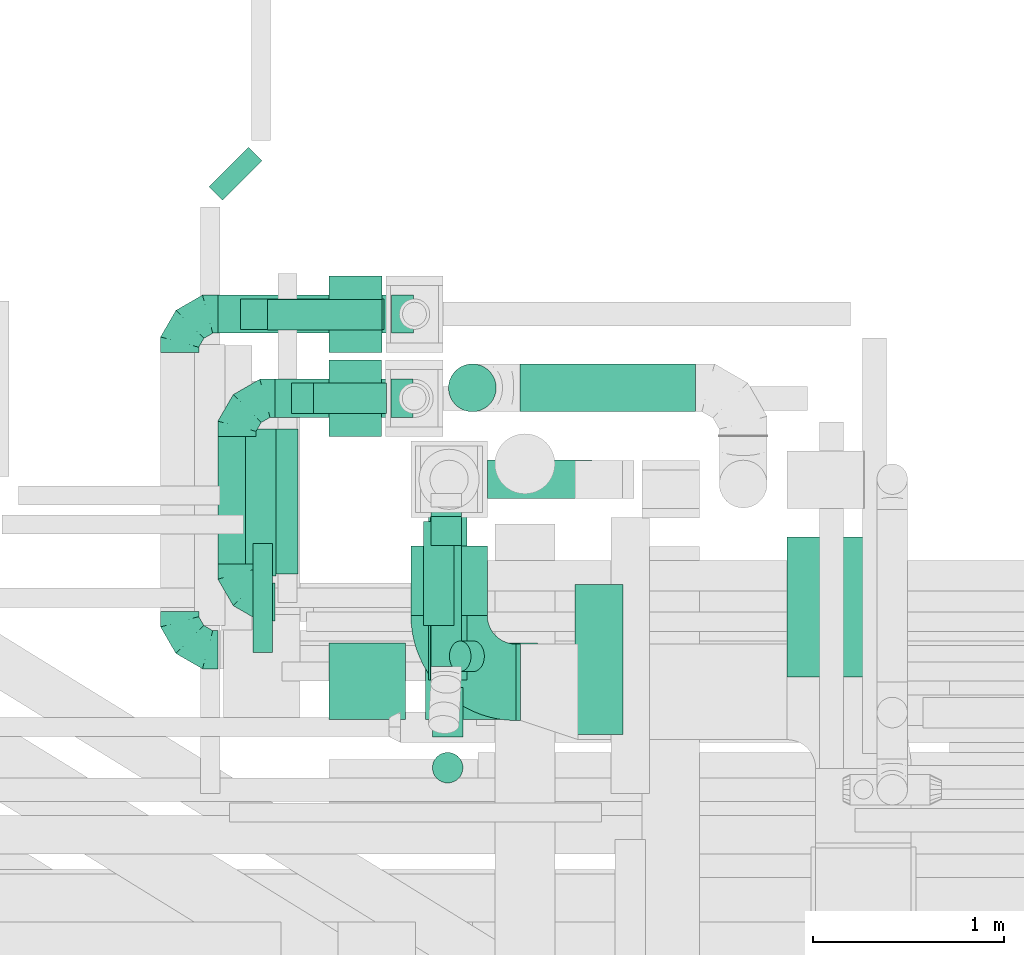
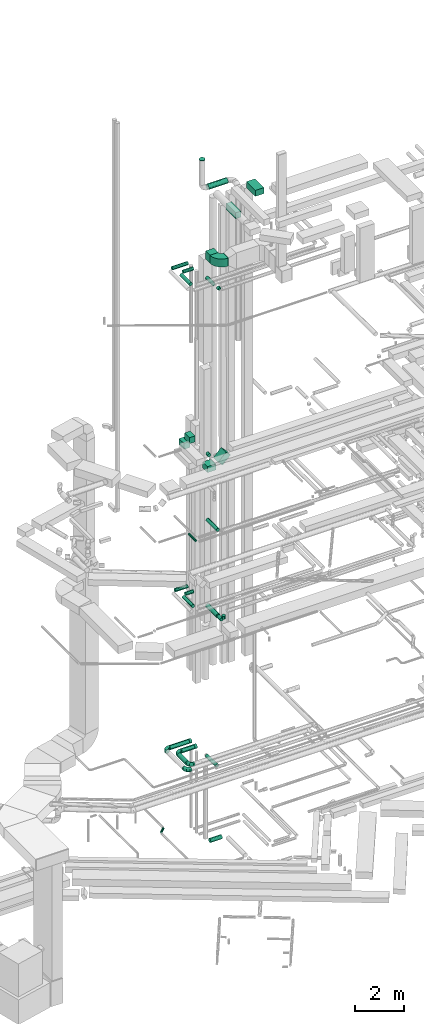
# One storey, part 97 of 337: 29 flow segments, 8 flow fittings.
"""IFC2X3 building model written with IfcOpenShell, lengths in millimetres."""

from ifc_helpers import new_model, entity, si_unit, converted_unit, derived_unit, direction, frame, frame_2d, origin, origin_2d_with_axis, place, context, subcontext, project, spatial, polyline, circle_curve, parameter, trimmed, segment, composite_curve, rectangle, circle, outline, extrude, faceted_brep, source, transform, mapped, material, type_object, type_shapes, element, save


model = new_model("IFC2X3")

# Units and contexts
model_context = context("Model", 3, precision=0.01, world=origin(), true_north=direction((6.12303176911189e-17, 1.0)))
body_context = subcontext(model_context, "Body", "Model", "MODEL_VIEW")
ifc_project = project(units=[si_unit("LENGTHUNIT", "METRE", prefix="MILLI"), si_unit("AREAUNIT", "SQUARE_METRE"), si_unit("VOLUMEUNIT", "CUBIC_METRE"), converted_unit("PLANEANGLEUNIT", "DEGREE", entity("IfcRatioMeasure", 0.0174532925199433), si_unit("PLANEANGLEUNIT", "RADIAN"), dimensions=[0, 0, 0, 0, 0, 0, 0]), si_unit("MASSUNIT", "GRAM", prefix="KILO"), derived_unit("MASSDENSITYUNIT", [(si_unit("MASSUNIT", "GRAM", prefix="KILO"), 1), (si_unit("LENGTHUNIT", "METRE"), -3)]), derived_unit("MOMENTOFINERTIAUNIT", [(si_unit("LENGTHUNIT", "METRE"), 4)]), si_unit("TIMEUNIT", "SECOND"), si_unit("FREQUENCYUNIT", "HERTZ"), si_unit("THERMODYNAMICTEMPERATUREUNIT", "DEGREE_CELSIUS"), derived_unit("THERMALTRANSMITTANCEUNIT", [(si_unit("MASSUNIT", "GRAM", prefix="KILO"), 1), (si_unit("THERMODYNAMICTEMPERATUREUNIT", "KELVIN"), -1), (si_unit("TIMEUNIT", "SECOND"), -3)]), derived_unit("VOLUMETRICFLOWRATEUNIT", [(si_unit("LENGTHUNIT", "METRE"), 3), (si_unit("TIMEUNIT", "SECOND"), -1)]), derived_unit("MASSFLOWRATEUNIT", [(si_unit("MASSUNIT", "GRAM", prefix="KILO"), 1), (si_unit("TIMEUNIT", "SECOND"), -1)]), derived_unit("ROTATIONALFREQUENCYUNIT", [(si_unit("TIMEUNIT", "SECOND"), -1)]), si_unit("ELECTRICCURRENTUNIT", "AMPERE"), si_unit("ELECTRICVOLTAGEUNIT", "VOLT"), si_unit("POWERUNIT", "WATT"), si_unit("FORCEUNIT", "NEWTON", prefix="KILO"), si_unit("ILLUMINANCEUNIT", "LUX"), si_unit("LUMINOUSFLUXUNIT", "LUMEN"), si_unit("LUMINOUSINTENSITYUNIT", "CANDELA"), derived_unit("USERDEFINED", [(si_unit("MASSUNIT", "GRAM", prefix="KILO"), -1), (si_unit("LENGTHUNIT", "METRE"), -2), (si_unit("TIMEUNIT", "SECOND"), 3), (si_unit("LUMINOUSFLUXUNIT", "LUMEN"), 1)]), derived_unit("LINEARVELOCITYUNIT", [(si_unit("LENGTHUNIT", "METRE"), 1), (si_unit("TIMEUNIT", "SECOND"), -1)]), si_unit("PRESSUREUNIT", "PASCAL"), derived_unit("USERDEFINED", [(si_unit("LENGTHUNIT", "METRE"), -2), (si_unit("MASSUNIT", "GRAM", prefix="KILO"), 1), (si_unit("TIMEUNIT", "SECOND"), -2)]), derived_unit("LINEARFORCEUNIT", [(si_unit("MASSUNIT", "GRAM", prefix="KILO"), 1), (si_unit("LENGTHUNIT", "METRE"), 1), (si_unit("TIMEUNIT", "SECOND"), -2), (si_unit("LENGTHUNIT", "METRE"), -1)]), derived_unit("PLANARFORCEUNIT", [(si_unit("MASSUNIT", "GRAM", prefix="KILO"), 1), (si_unit("LENGTHUNIT", "METRE"), 1), (si_unit("TIMEUNIT", "SECOND"), -2), (si_unit("LENGTHUNIT", "METRE"), -2)])], contexts=[model_context])

# Site, building, storey
site_placement = place(None, origin())
site = spatial("IfcSite", under=ifc_project, at=site_placement, CompositionType="ELEMENT")
building_placement = place(site_placement, origin())
building = spatial("IfcBuilding", under=site, at=building_placement, CompositionType="ELEMENT")
storey_placement = place(building_placement, origin())
storey = spatial("IfcBuildingStorey", under=building, at=storey_placement, CompositionType="ELEMENT", Elevation=0.0)

# Flow segments
duct_segment_type_1 = type_object("IfcDuctSegmentType", PredefinedType="NOTDEFINED")
flow_segment_1_placement = place(storey_placement, frame((7575.26, 14600.63, 18500.0)))
element("IfcFlowSegment", 1, at=flow_segment_1_placement, inside=storey, type_object=duct_segment_type_1, context=body_context, shape_type="SweptSolid", body=[
    extrude(rectangle(XDim=278.301854356644, YDim=400.0, at=origin_2d_with_axis()), frame((139.15, 200.0, 0.0), z_axis=(0.0, 0.0, 1.0), x_axis=(-1.0, 0.0, 0.0)), (0.0, 0.0, 1.0), 300.000000000001),
])
flow_segment_2_placement = place(storey_placement, frame((7574.85, 14159.28, 19050.0)))
element("IfcFlowSegment", 2, at=flow_segment_2_placement, inside=storey, type_object=duct_segment_type_1, context=body_context, shape_type="SweptSolid", body=[
    extrude(rectangle(XDim=276.813591924487, YDim=400.0, at=origin_2d_with_axis()), frame((138.41, 200.0, 0.0), z_axis=(0.0, 0.0, 1.0), x_axis=(-1.0, 0.0, 0.0)), (0.0, 0.0, 1.0), 300.000000000001),
])
flow_segment_3_placement = place(storey_placement, frame((8082.06, 12678.06, 18631.8)))
element("IfcFlowSegment", 3, at=flow_segment_3_placement, inside=storey, type_object=duct_segment_type_1, context=body_context, shape_type="SweptSolid", body=[
    extrude(rectangle(XDim=300.000000000002, YDim=400.000000000002, at=frame_2d((0.0, 0.0), x_axis=(0.0, 1.0))), frame((106.07, 200.0, 106.07), z_axis=(0.70710678118651, 0.0, 0.707106781186585), x_axis=(0.0, 1.0, 0.0)), (0.0, 0.0, 1.0), 529.2893218813),
])
flow_segment_4_placement = place(storey_placement, frame((7575.26, 12678.06, 18500.0)))
element("IfcFlowSegment", 4, at=flow_segment_4_placement, inside=storey, type_object=duct_segment_type_1, context=body_context, shape_type="SweptSolid", body=[
    extrude(rectangle(XDim=400.735931288126, YDim=400.0, at=origin_2d_with_axis()), frame((200.37, 200.0, 0.0)), (0.0, 0.0, 1.0), 300.000000000001),
])
flow_segment_5_placement = place(storey_placement, frame((8004.69, 13222.81, 28500.0)))
element("IfcFlowSegment", 5, at=flow_segment_5_placement, inside=storey, type_object=duct_segment_type_1, context=body_context, shape_type="SweptSolid", body=[
    extrude(rectangle(XDim=362.88164353834, YDim=400.0, at=origin_2d_with_axis()), frame((200.0, 181.44, 0.0), z_axis=(0.0, 0.0, 1.0), x_axis=(0.0, 1.0, 0.0)), (0.0, 0.0, 1.0), 399.999999999996),
])
flow_segment_6_placement = place(storey_placement, frame((8554.69, 12672.81, 28500.0)))
element("IfcFlowSegment", 6, at=flow_segment_6_placement, inside=storey, type_object=duct_segment_type_1, context=body_context, shape_type="SweptSolid", body=[
    extrude(rectangle(XDim=25.0000000006874, YDim=400.0, at=origin_2d_with_axis()), frame((12.5, 200.0, 0.0)), (0.0, 0.0, 1.0), 399.999999999996),
])
duct_segment_type_2 = type_object("IfcDuctSegmentType", PredefinedType="NOTDEFINED")
flow_segment_7_placement = place(storey_placement, frame((8404.69, 13834.09, -1051.6)))
element("IfcFlowSegment", 7, at=flow_segment_7_placement, inside=storey, type_object=duct_segment_type_2, context=body_context, shape_type="SweptSolid", body=[
    extrude(circle(Radius=100.0, at=origin_2d_with_axis()), frame((0.0, 101.6, 101.6), z_axis=(1.0, 0.0, 0.0), x_axis=(0.0, 1.0, 0.0)), (0.0, 0.0, 1.0), 548.553559999927),
])
flow_segment_8_placement = place(storey_placement, frame((6946.37, 15395.93, -1001.6)))
element("IfcFlowSegment", 8, at=flow_segment_8_placement, inside=storey, type_object=duct_segment_type_2, context=body_context, shape_type="SweptSolid", body=[
    extrude(circle(Radius=50.0, at=origin_2d_with_axis()), frame((36.95, 36.95, 51.6), z_axis=(0.707106781186605, 0.70710678118649, 0.0), x_axis=(0.70710678118649, -0.707106781186605, 0.0)), (0.0, 0.0, 1.0), 291.818961050026),
])
flow_segment_9_placement = place(storey_placement, frame((8095.73, 12885.69, 10898.4)))
element("IfcFlowSegment", 9, at=flow_segment_9_placement, inside=storey, type_object=duct_segment_type_2, context=body_context, shape_type="SweptSolid", body=[
    extrude(circle(Radius=100.0, at=origin_2d_with_axis()), frame((101.6, 0.0, 101.6), z_axis=(0.0, 1.0, 0.0), x_axis=(-1.0, 0.0, 0.0)), (0.0, 0.0, 1.0), 855.000000000102),
])
flow_segment_10_placement = place(storey_placement, frame((7493.56, 14278.67, 11368.4)))
element("IfcFlowSegment", 10, at=flow_segment_10_placement, inside=storey, type_object=duct_segment_type_2, context=body_context, shape_type="SweptSolid", body=[
    extrude(circle(Radius=80.0, at=origin_2d_with_axis()), frame((0.0, 81.6, 81.6), z_axis=(1.0, 0.0, 0.0), x_axis=(0.0, -1.0, 0.0)), (0.0, 0.0, 1.0), 383.103797171607),
])
flow_segment_11_placement = place(storey_placement, frame((7251.97, 13440.27, 11368.4)))
element("IfcFlowSegment", 11, at=flow_segment_11_placement, inside=storey, type_object=duct_segment_type_2, context=body_context, shape_type="SweptSolid", body=[
    extrude(circle(Radius=80.0, at=origin_2d_with_axis()), frame((81.6, 0.0, 81.6), z_axis=(0.0, 1.0, 0.0), x_axis=(-1.0, 0.0, 0.0)), (0.0, 0.0, 1.0), 760.000000000037),
])
flow_segment_12_placement = place(storey_placement, frame((7294.17, 14258.03, 3558.4)))
element("IfcFlowSegment", 12, at=flow_segment_12_placement, inside=storey, type_object=duct_segment_type_2, context=body_context, shape_type="SweptSolid", body=[
    extrude(circle(Radius=100.0, at=origin_2d_with_axis()), frame((0.0, 101.6, 101.6), z_axis=(1.0, 0.0, 0.0), x_axis=(0.0, -1.0, 0.0)), (0.0, 0.0, 1.0), 607.500000000005),
])
flow_segment_13_placement = place(storey_placement, frame((6992.57, 13493.38, 3558.4)))
element("IfcFlowSegment", 13, at=flow_segment_13_placement, inside=storey, type_object=duct_segment_type_2, context=body_context, shape_type="SweptSolid", body=[
    extrude(circle(Radius=100.0, at=origin_2d_with_axis()), frame((101.6, 0.0, 101.6), z_axis=(0.0, 1.0, 0.0), x_axis=(-1.0, 0.0, 0.0)), (0.0, 0.0, 1.0), 666.250000000018),
])
flow_segment_14_placement = place(storey_placement, frame((6994.13, 14698.87, 3558.4)))
element("IfcFlowSegment", 14, at=flow_segment_14_placement, inside=storey, type_object=duct_segment_type_2, context=body_context, shape_type="SweptSolid", body=[
    extrude(circle(Radius=100.0, at=origin_2d_with_axis()), frame((0.0, 101.6, 101.6), z_axis=(1.0, 0.0, 0.0), x_axis=(0.0, -1.0, 0.0)), (0.0, 0.0, 1.0), 909.40808920135),
])
flow_segment_15_placement = place(storey_placement, frame((8108.1, 12956.4, 3378.4)))
element("IfcFlowSegment", 15, at=flow_segment_15_placement, inside=storey, type_object=duct_segment_type_2, context=body_context, shape_type="SweptSolid", body=[
    extrude(circle(Radius=80.0, at=origin_2d_with_axis()), frame((81.6, 0.0, 81.6), z_axis=(0.0, 1.0, 0.0), x_axis=(-1.0, 0.0, 0.0)), (0.0, 0.0, 1.0), 835.195242005169),
])
flow_segment_16_placement = place(storey_placement, frame((8105.73, 12885.69, 15218.4)))
element("IfcFlowSegment", 16, at=flow_segment_16_placement, inside=storey, type_object=duct_segment_type_2, context=body_context, shape_type="SweptSolid", body=[
    extrude(circle(Radius=80.0, at=origin_2d_with_axis()), frame((81.6, 0.0, 81.6), z_axis=(0.0, 1.0, 0.0), x_axis=(1.0, 0.0, 0.0)), (0.0, 0.0, 1.0), 855.00000000004),
])
flow_segment_17_placement = place(storey_placement, frame((7177.72, 13030.0, 14948.4)))
element("IfcFlowSegment", 17, at=flow_segment_17_placement, inside=storey, type_object=duct_segment_type_2, context=body_context, shape_type="SweptSolid", body=[
    extrude(circle(Radius=50.0, at=origin_2d_with_axis()), frame((51.6, 0.0, 51.6), z_axis=(0.0, 1.0, 0.0), x_axis=(1.0, 0.0, 0.0)), (0.0, 0.0, 1.0), 570.000000000031),
])
flow_segment_18_placement = place(storey_placement, frame((7253.56, 14715.12, 11368.4)))
element("IfcFlowSegment", 18, at=flow_segment_18_placement, inside=storey, type_object=duct_segment_type_2, context=body_context, shape_type="SweptSolid", body=[
    extrude(circle(Radius=80.0, at=origin_2d_with_axis()), frame((0.0, 81.6, 81.6), z_axis=(1.0, 0.0, 0.0), x_axis=(0.0, -1.0, 0.0)), (0.0, 0.0, 1.0), 599.999999999878),
])
flow_segment_19_placement = place(storey_placement, frame((8115.73, 12585.69, 10918.4)))
element("IfcFlowSegment", 19, at=flow_segment_19_placement, inside=storey, type_object=duct_segment_type_2, context=body_context, shape_type="SweptSolid", body=[
    extrude(circle(Radius=80.0, at=origin_2d_with_axis()), frame((81.6, 0.0, 81.6), z_axis=(0.0, 1.0, 0.0), x_axis=(-1.0, 0.0, 0.0)), (0.0, 0.0, 1.0), 260.000000000025),
])
flow_segment_20_placement = place(storey_placement, frame((8115.73, 12344.09, 11160.0)))
element("IfcFlowSegment", 20, at=flow_segment_20_placement, inside=storey, type_object=duct_segment_type_2, context=body_context, shape_type="SweptSolid", body=[
    extrude(circle(Radius=80.0, at=origin_2d_with_axis()), frame((81.6, 81.6, 0.0)), (0.0, 0.0, 1.0), 150.000000000053),
])
flow_segment_21_placement = place(storey_placement, frame((8108.1, 13590.35, 18528.4)))
element("IfcFlowSegment", 21, at=flow_segment_21_placement, inside=storey, type_object=duct_segment_type_2, context=body_context, shape_type="SweptSolid", body=[
    extrude(circle(Radius=80.0, at=origin_2d_with_axis()), frame((81.6, 0.0, 81.6), z_axis=(0.0, 1.0, 0.0), x_axis=(-1.0, 0.0, 0.0)), (0.0, 0.0, 1.0), 150.340764961465),
])
flow_segment_22_placement = place(storey_placement, frame((7112.18, 14718.87, 27518.4)))
element("IfcFlowSegment", 22, at=flow_segment_22_placement, inside=storey, type_object=duct_segment_type_2, context=body_context, shape_type="SweptSolid", body=[
    extrude(circle(Radius=80.0, at=origin_2d_with_axis()), frame((0.0, 81.6, 81.6), z_axis=(1.0, 0.0, 0.0), x_axis=(0.0, 1.0, 0.0)), (0.0, 0.0, 1.0), 751.379026910381),
])
flow_segment_23_placement = place(storey_placement, frame((7379.47, 14277.83, 27518.4)))
element("IfcFlowSegment", 23, at=flow_segment_23_placement, inside=storey, type_object=duct_segment_type_2, context=body_context, shape_type="SweptSolid", body=[
    extrude(circle(Radius=80.0, at=origin_2d_with_axis()), frame((0.0, 81.6, 81.6), z_axis=(1.0, 0.0, 0.0), x_axis=(0.0, 1.0, 0.0)), (0.0, 0.0, 1.0), 482.196560462836),
])
flow_segment_24_placement = place(storey_placement, frame((7137.84, 13429.96, 27518.4)))
element("IfcFlowSegment", 24, at=flow_segment_24_placement, inside=storey, type_object=duct_segment_type_2, context=body_context, shape_type="SweptSolid", body=[
    extrude(circle(Radius=80.0, at=origin_2d_with_axis()), frame((81.6, 0.0, 81.6), z_axis=(0.0, 1.0, 0.0), x_axis=(-1.0, 0.0, 0.0)), (0.0, 0.0, 1.0), 769.468388366114),
])
flow_segment_25_placement = place(storey_placement, frame((8068.1, 13169.26, 27348.4)))
element("IfcFlowSegment", 25, at=flow_segment_25_placement, inside=storey, type_object=duct_segment_type_2, context=body_context, shape_type="SweptSolid", body=[
    extrude(circle(Radius=80.0, at=origin_2d_with_axis()), frame((81.6, 0.0, 81.6), z_axis=(0.0, 1.0, 0.0), x_axis=(-1.0, 0.0, 0.0)), (0.0, 0.0, 1.0), 546.426253024174),
])
flow_segment_26_placement = place(storey_placement, frame((8576.39, 14288.14, 31273.7)))
element("IfcFlowSegment", 26, at=flow_segment_26_placement, inside=storey, type_object=duct_segment_type_2, context=body_context, shape_type="SweptSolid", body=[
    extrude(circle(Radius=125.0, at=origin_2d_with_axis()), frame((0.0, 126.6, 126.6), z_axis=(1.0, 0.0, 0.0), x_axis=(0.0, 1.0, 0.0)), (0.0, 0.0, 1.0), 918.063977471099),
])
flow_segment_27_placement = place(storey_placement, frame((8204.67, 12927.67, 27188.7)))
element("IfcFlowSegment", 27, at=flow_segment_27_placement, inside=storey, type_object=duct_segment_type_2, context=body_context, shape_type="SweptSolid", body=[
    extrude(circle(Radius=80.0, at=origin_2d_with_axis()), frame((58.16, 81.6, 128.16), z_axis=(0.707106781186541, 0.0, -0.707106781186554), x_axis=(0.0, 1.0, 0.0)), (0.0, 0.0, 1.0), 98.9949493661142),
])
duct_segment_type_3 = type_object("IfcDuctSegmentType", PredefinedType="NOTDEFINED")
flow_segment_28_placement = place(storey_placement, frame((9973.95, 12899.6, 31350.0)))
element("IfcFlowSegment", 28, at=flow_segment_28_placement, inside=storey, type_object=duct_segment_type_3, context=body_context, shape_type="SweptSolid", body=[
    extrude(rectangle(XDim=734.413460000079, YDim=400.0, at=origin_2d_with_axis()), frame((200.0, 367.21, 0.0), z_axis=(0.0, 0.0, 1.0), x_axis=(0.0, 1.0, 0.0)), (0.0, 0.0, 1.0), 300.000000000001),
])
flow_segment_29_placement = place(storey_placement, frame((8863.91, 12599.6, 30800.0)))
element("IfcFlowSegment", 29, at=flow_segment_29_placement, inside=storey, type_object=duct_segment_type_3, context=body_context, shape_type="SweptSolid", body=[
    extrude(rectangle(XDim=784.286964999949, YDim=250.000000000001, at=origin_2d_with_axis()), frame((125.0, 392.14, 0.0), z_axis=(0.0, 0.0, 1.0), x_axis=(0.0, 1.0, 0.0)), (0.0, 0.0, 1.0), 300.000000000001),
])

# Flow fittings
ifc_material = material()
duct_fitting_type_1 = type_object("IfcDuctFittingType", PredefinedType="NOTDEFINED", material=ifc_material)
shared_shape_1 = source(origin(), body_context, "Body", "SweptSolid", [
    extrude(circle(Radius=124.999999999999, at=origin_2d_with_axis()), frame((0.0, 0.0, 0.0), z_axis=(1.0, 0.0, 0.0), x_axis=(0.0, 1.0, 0.0)), (0.0, 0.0, 1.0), 25.0000000000018),
])
type_shapes(duct_fitting_type_1, [shared_shape_1])
flow_fitting_1_placement = place(storey_placement, frame((8326.39, 14414.61, 32860.29), z_axis=(0.0, -1.0, 0.0), x_axis=(0.0, 0.0, 1.0)))
element("IfcFlowFitting", 30, at=flow_fitting_1_placement, inside=storey, type_object=duct_fitting_type_1, material=ifc_material, context=body_context, shape_type="MappedRepresentation", body=[
    mapped(shared_shape_1, transform((0.0, 0.0, 0.0), scale=1.0)),
])
duct_fitting_type_2 = type_object("IfcDuctFittingType", PredefinedType="NOTDEFINED", material=ifc_material)
shared_shape_2 = source(origin(), body_context, "Body", "Brep", [
    faceted_brep([(-200.0, 0.0, -100.0), (-200.0, -25.88, -96.59), (-200.0, -50.0, -86.6), (-200.0, -70.71, -70.71), (-200.0, -86.6, -50.0), (-200.0, -96.59, -25.88), (-200.0, -100.0, 0.0), (-200.0, -96.59, 25.88), (-200.0, -86.6, 50.0), (-200.0, -70.71, 70.71), (-200.0, -50.0, 86.6), (-200.0, -25.88, 96.59), (-200.0, 0.0, 100.0), (-200.0, 25.88, 96.59), (-200.0, 50.0, 86.6), (-200.0, 70.71, 70.71), (-200.0, 86.6, 50.0), (-200.0, 96.59, 25.88), (-200.0, 100.0, 0.0), (-200.0, 96.59, -25.88), (-200.0, 86.6, -50.0), (-200.0, 70.71, -70.71), (-200.0, 50.0, -86.6), (-200.0, 25.88, -96.59), (-153.35, 25.88, 96.59), (-159.81, 50.0, 86.6), (-146.41, 0.0, 100.0), (-165.36, 70.71, 70.71), (-172.29, 96.59, 25.88), (-173.21, 100.0, 0.0), (-169.62, 86.6, 50.0), (-169.62, 86.6, -50.0), (-165.36, 70.71, -70.71), (-172.29, 96.59, -25.88), (-153.35, 25.88, -96.59), (-146.41, 0.0, -100.0), (-159.81, 50.0, -86.6), (-139.48, -25.88, -96.59), (-133.01, -50.0, -86.6), (-127.46, -70.71, -70.71), (-123.21, -86.6, -50.0), (-120.53, -96.59, -25.88), (-119.62, -100.0, 0.0), (-120.53, -96.59, 25.88), (-123.21, -86.6, 50.0), (-127.46, -70.71, 70.71), (-133.01, -50.0, 86.6), (-139.48, -25.88, 96.59), (-72.54, 72.54, 96.59), (-90.19, 90.19, 86.6), (-53.59, 53.59, 100.0), (-105.35, 105.35, 70.71), (-116.99, 116.99, 50.0), (-124.3, 124.3, 25.88), (-126.79, 126.79, 0.0), (-124.3, 124.3, -25.88), (-116.99, 116.99, -50.0), (-105.35, 105.35, -70.71), (-72.54, 72.54, -96.59), (-53.59, 53.59, -100.0), (-90.19, 90.19, -86.6), (-34.64, 34.64, -96.59), (-16.99, 16.99, -86.6), (-1.83, 1.83, -70.71), (9.81, -9.81, -50.0), (17.12, -17.12, -25.88), (19.62, -19.62, 0.0), (17.12, -17.12, 25.88), (9.81, -9.81, 50.0), (-1.83, 1.83, 70.71), (-16.99, 16.99, 86.6), (-34.64, 34.64, 96.59), (-25.88, 153.35, 96.59), (-50.0, 159.81, 86.6), (0.0, 146.41, 100.0), (-70.71, 165.36, 70.71), (-86.6, 169.62, 50.0), (-96.59, 172.29, 25.88), (-100.0, 173.21, 0.0), (-96.59, 172.29, -25.88), (-86.6, 169.62, -50.0), (-70.71, 165.36, -70.71), (-25.88, 153.35, -96.59), (0.0, 146.41, -100.0), (-50.0, 159.81, -86.6), (25.88, 139.48, -96.59), (50.0, 133.01, -86.6), (70.71, 127.46, -70.71), (86.6, 123.21, -50.0), (96.59, 120.53, -25.88), (100.0, 119.62, 0.0), (96.59, 120.53, 25.88), (86.6, 123.21, 50.0), (70.71, 127.46, 70.71), (50.0, 133.01, 86.6), (25.88, 139.48, 96.59), (-25.88, 200.0, -96.59), (-50.0, 200.0, -86.6), (-70.71, 200.0, -70.71), (-86.6, 200.0, -50.0), (-96.59, 200.0, -25.88), (-100.0, 200.0, 0.0), (-96.59, 200.0, 25.88), (-86.6, 200.0, 50.0), (-70.71, 200.0, 70.71), (-50.0, 200.0, 86.6), (-25.88, 200.0, 96.59), (0.0, 200.0, 100.0), (25.88, 200.0, 96.59), (50.0, 200.0, 86.6), (70.71, 200.0, 70.71), (86.6, 200.0, 50.0), (96.59, 200.0, 25.88), (100.0, 200.0, 0.0), (96.59, 200.0, -25.88), (86.6, 200.0, -50.0), (70.71, 200.0, -70.71), (50.0, 200.0, -86.6), (25.88, 200.0, -96.59), (0.0, 200.0, -100.0)], [[[0, 1, 2, 3, 4, 5, 6, 7, 8, 9, 10, 11, 12, 13, 14, 15, 16, 17, 18, 19, 20, 21, 22, 23]], [[24, 25, 14, 13]], [[26, 24, 13, 12]], [[14, 25, 27, 15]], [[28, 29, 18, 17]], [[30, 28, 17, 16]], [[15, 27, 30, 16]], [[20, 31, 32, 21]], [[33, 31, 20, 19]], [[18, 29, 33, 19]], [[34, 35, 0, 23]], [[36, 34, 23, 22]], [[32, 36, 22, 21]], [[1, 0, 35, 37]], [[2, 1, 37, 38]], [[38, 39, 3, 2]], [[5, 4, 40, 41]], [[6, 5, 41, 42]], [[39, 40, 4, 3]], [[6, 42, 43, 7]], [[7, 43, 44, 8]], [[8, 44, 45, 9]], [[9, 45, 46, 10]], [[10, 46, 47, 11]], [[26, 12, 11, 47]], [[48, 49, 25, 24]], [[50, 48, 24, 26]], [[27, 25, 49, 51]], [[52, 53, 28, 30]], [[51, 52, 30, 27]], [[29, 28, 53, 54]], [[55, 56, 31, 33]], [[54, 55, 33, 29]], [[32, 31, 56, 57]], [[58, 59, 35, 34]], [[60, 58, 34, 36]], [[57, 60, 36, 32]], [[37, 35, 59, 61]], [[38, 37, 61, 62]], [[39, 38, 62, 63]], [[41, 40, 64, 65]], [[42, 41, 65, 66]], [[63, 64, 40, 39]], [[43, 42, 66, 67]], [[44, 43, 67, 68]], [[68, 69, 45, 44]], [[46, 45, 69, 70]], [[47, 46, 70, 71]], [[26, 47, 71, 50]], [[72, 73, 49, 48]], [[74, 72, 48, 50]], [[51, 49, 73, 75]], [[76, 77, 53, 52]], [[75, 76, 52, 51]], [[54, 53, 77, 78]], [[79, 80, 56, 55]], [[78, 79, 55, 54]], [[57, 56, 80, 81]], [[82, 83, 59, 58]], [[84, 82, 58, 60]], [[81, 84, 60, 57]], [[61, 59, 83, 85]], [[62, 61, 85, 86]], [[63, 62, 86, 87]], [[65, 64, 88, 89]], [[66, 65, 89, 90]], [[87, 88, 64, 63]], [[67, 66, 90, 91]], [[68, 67, 91, 92]], [[92, 93, 69, 68]], [[70, 69, 93, 94]], [[71, 70, 94, 95]], [[50, 71, 95, 74]], [[96, 97, 98, 99, 100, 101, 102, 103, 104, 105, 106, 107, 108, 109, 110, 111, 112, 113, 114, 115, 116, 117, 118, 119]], [[72, 74, 107, 106]], [[73, 72, 106, 105]], [[75, 73, 105, 104]], [[102, 101, 78, 77]], [[103, 102, 77, 76]], [[75, 104, 103, 76]], [[78, 101, 100, 79]], [[79, 100, 99, 80]], [[80, 99, 98, 81]], [[84, 97, 96, 82]], [[82, 96, 119, 83]], [[84, 81, 98, 97]], [[118, 117, 86, 85]], [[119, 118, 85, 83]], [[116, 87, 86, 117]], [[88, 115, 114, 89]], [[89, 114, 113, 90]], [[115, 88, 87, 116]], [[91, 90, 113, 112]], [[92, 91, 112, 111]], [[111, 110, 93, 92]], [[95, 94, 109, 108]], [[74, 95, 108, 107]], [[110, 109, 94, 93]]]),
])
type_shapes(duct_fitting_type_2, [shared_shape_2])
for number, where, z_axis, x_axis in (
    (31, (7094.17, 14359.63, 3660.0), (0.0, 0.0, 1.0), (-1.0, 0.0, 0.0)),
    (32, (6794.13, 13043.34, 3660.0), (0.0, 0.0, 1.0), (0.0, -1.0, 0.0)),
    (33, (7094.17, 13293.38, 3660.0), (0.0, 0.0, 1.0), (0.0, -1.0, 0.0)),
    (34, (6794.13, 14800.39, 3660.0), (0.0, 0.0, 1.0), (-1.0, 0.0, 0.0)),
):
    element("IfcFlowFitting", number, at=place(storey_placement, frame(where, z_axis=z_axis, x_axis=x_axis)), inside=storey, type_object=duct_fitting_type_2, material=ifc_material, context=body_context, shape_type="MappedRepresentation", body=[
        mapped(shared_shape_2, transform((0.0, 0.0, 0.0), scale=1.0)),
    ])
duct_fitting_type_3 = type_object("IfcDuctFittingType", PredefinedType="NOTDEFINED", material=ifc_material)
shared_shape_3 = source(origin(), body_context, "Body", "Brep", [
    faceted_brep([(20.0, 25.88, -96.59), (20.0, 50.0, -86.6), (20.0, 70.71, -70.71), (20.0, 86.6, -50.0), (20.0, 96.59, -25.88), (20.0, 100.0, 0.0), (20.0, 96.59, 25.88), (20.0, 86.6, 50.0), (20.0, 70.71, 70.71), (20.0, 50.0, 86.6), (20.0, 25.88, 96.59), (20.0, 0.0, 100.0), (20.0, -25.88, 96.59), (20.0, -50.0, 86.6), (20.0, -70.71, 70.71), (20.0, -86.6, 50.0), (20.0, -96.59, 25.88), (20.0, -100.0, 0.0), (20.0, -96.59, -25.88), (20.0, -86.6, -50.0), (20.0, -70.71, -70.71), (20.0, -50.0, -86.6), (20.0, -25.88, -96.59), (20.0, 0.0, -100.0), (0.0, 0.0, 100.0), (0.0, 25.88, 96.59), (-93.9, 25.88, 96.59), (-93.9, 0.0, 100.0), (0.0, 50.0, 86.6), (-93.9, 50.0, 86.6), (0.0, 70.71, 70.71), (-93.9, 70.71, 70.71), (0.0, 86.6, 50.0), (0.0, 96.59, 25.88), (-93.9, 96.59, 25.88), (-93.9, 86.6, 50.0), (0.0, 100.0, 0.0), (-93.9, 100.0, 0.0), (0.0, 96.59, -25.88), (-93.9, 96.59, -25.88), (0.0, 86.6, -50.0), (-93.9, 86.6, -50.0), (0.0, 70.71, -70.71), (-93.9, 70.71, -70.71), (0.0, 50.0, -86.6), (0.0, 25.88, -96.59), (-93.9, 25.88, -96.59), (-93.9, 50.0, -86.6), (0.0, 0.0, -100.0), (-93.9, 0.0, -100.0), (0.0, -25.88, -96.59), (-93.9, -25.88, -96.59), (0.0, -50.0, -86.6), (-93.9, -50.0, -86.6), (0.0, -70.71, -70.71), (-93.9, -70.71, -70.71), (0.0, -86.6, -50.0), (0.0, -96.59, -25.88), (-93.9, -96.59, -25.88), (-93.9, -86.6, -50.0), (0.0, -100.0, 0.0), (-93.9, -100.0, 0.0), (0.0, -96.59, 25.88), (-93.9, -96.59, 25.88), (0.0, -86.6, 50.0), (-93.9, -86.6, 50.0), (0.0, -70.71, 70.71), (-93.9, -70.71, 70.71), (0.0, -50.0, 86.6), (0.0, -25.88, 96.59), (-93.9, -25.88, 96.59), (-93.9, -50.0, 86.6)], [[[0, 1, 2, 3, 4, 5, 6, 7, 8, 9, 10, 11, 12, 13, 14, 15, 16, 17, 18, 19, 20, 21, 22, 23]], [[24, 11, 10, 25, 26, 27]], [[25, 10, 9, 28, 29, 26]], [[28, 9, 8, 30, 31, 29]], [[32, 7, 6, 33, 34, 35]], [[33, 6, 5, 36, 37, 34]], [[30, 8, 7, 32, 35, 31]], [[36, 5, 4, 38, 39, 37]], [[38, 4, 3, 40, 41, 39]], [[40, 3, 2, 42, 43, 41]], [[44, 1, 0, 45, 46, 47]], [[45, 0, 23, 48, 49, 46]], [[42, 2, 1, 44, 47, 43]], [[48, 23, 22, 50, 51, 49]], [[50, 22, 21, 52, 53, 51]], [[52, 21, 20, 54, 55, 53]], [[56, 19, 18, 57, 58, 59]], [[57, 18, 17, 60, 61, 58]], [[54, 20, 19, 56, 59, 55]], [[60, 17, 16, 62, 63, 61]], [[62, 16, 15, 64, 65, 63]], [[64, 15, 14, 66, 67, 65]], [[68, 13, 12, 69, 70, 71]], [[69, 12, 11, 24, 27, 70]], [[66, 14, 13, 68, 71, 67]], [[49, 51, 53, 55, 59, 58, 61, 63, 65, 67, 71, 70, 27, 26, 29, 31, 35, 34, 37, 39, 41, 43, 47, 46]]]),
])
type_shapes(duct_fitting_type_3, [shared_shape_3])
for number, where, z_axis, x_axis in (
    (35, (7921.67, 14359.63, 3660.0), (0.0, 1.0, 0.0), (-1.0, 0.0, 0.0)),
    (36, (7923.54, 14800.47, 3660.0), (0.0, 1.0, 0.0), (-1.0, 0.0, 0.0)),
):
    element("IfcFlowFitting", number, at=place(storey_placement, frame(where, z_axis=z_axis, x_axis=x_axis)), inside=storey, type_object=duct_fitting_type_3, material=ifc_material, context=body_context, shape_type="MappedRepresentation", body=[
        mapped(shared_shape_3, transform((0.0, 0.0, 0.0), scale=1.0)),
    ])
duct_fitting_type_4 = type_object("IfcDuctFittingType", PredefinedType="NOTDEFINED", material=ifc_material)
shared_shape_4 = source(origin(), body_context, "Body", "SweptSolid", [
    extrude(outline(composite_curve([segment(polyline([(-375.0, -175.0), (25.0, -175.0)]), True, "CONTINUOUS"), segment(trimmed(circle_curve(frame_2d((175.0, -175.0), x_axis=(0.0, 1.0)), 150.0), [parameter(0.0)], [parameter(90.0)], True, "PARAMETER"), False, "CONTINUOUS"), segment(polyline([(175.0, -25.0), (175.0, 375.0)]), True, "CONTINUOUS"), segment(trimmed(circle_curve(frame_2d((175.0, -175.0), x_axis=(0.0, 1.0)), 550.0), [parameter(0.0)], [parameter(90.0)], True, "PARAMETER"), True, "CONTINUOUS")], self_intersect=False)), frame((-175.0, 175.0, -200.0), z_axis=(0.0, 0.0, 1.0), x_axis=(-1.0, 0.0, 0.0)), (0.0, 0.0, 1.0), 400.0),
])
type_shapes(duct_fitting_type_4, [shared_shape_4])
flow_fitting_2_placement = place(storey_placement, frame((8204.69, 12872.81, 28700.0), z_axis=(0.0, 0.0, 1.0), x_axis=(0.0, -1.0, 0.0)))
element("IfcFlowFitting", 37, at=flow_fitting_2_placement, inside=storey, type_object=duct_fitting_type_4, material=ifc_material, context=body_context, shape_type="MappedRepresentation", body=[
    mapped(shared_shape_4, transform((0.0, 0.0, 0.0), scale=1.0)),
])

save(model, "model.ifc")
